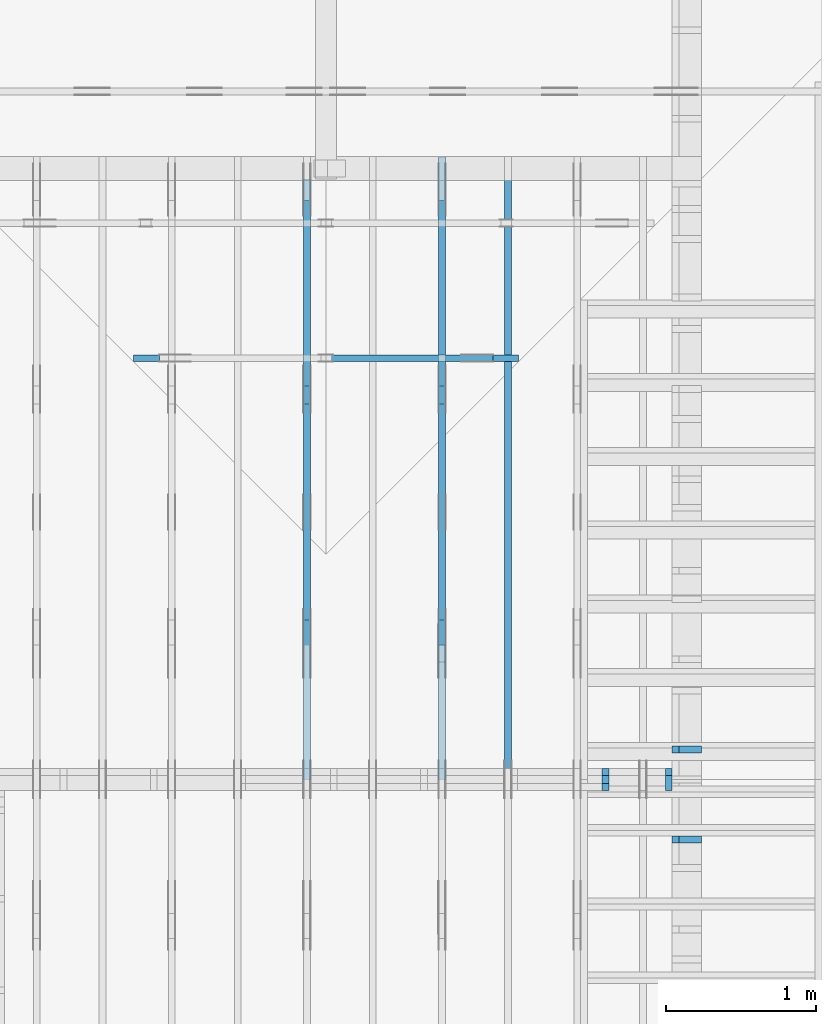
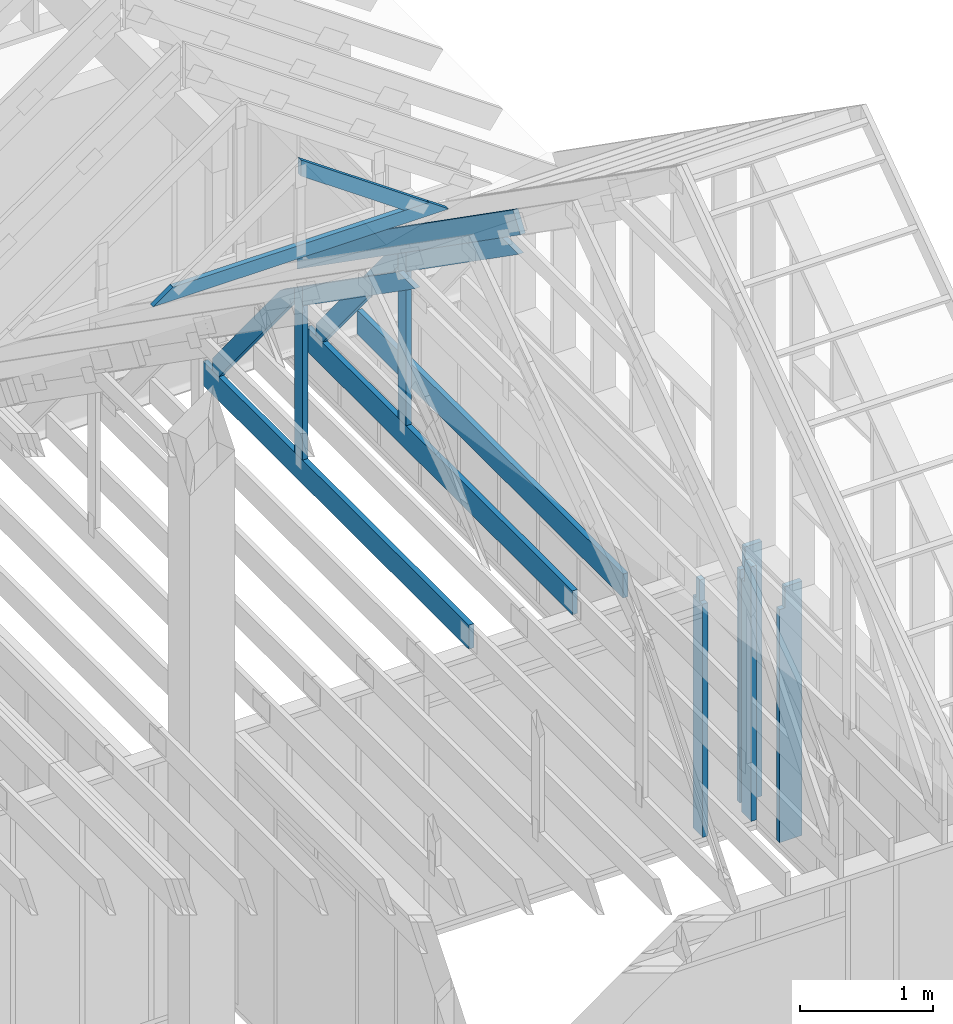
# One storey, part 26 of 70: 16 members, 6 elements without a shape of their own.
"""IFC2X3 building model written with IfcOpenShell, lengths in millimetres."""

from ifc_helpers import new_model, si_unit, frame, origin, origin_with_axes, origin_2d, place, context, project, spatial, faceted_brep, element, aggregate, save


model = new_model("IFC2X3")

# Units and contexts
model_context = context("Model", 3, precision=1e-05, world=origin())
plan_context = context("Plan", 2, precision=1e-05, world=origin_2d())
ifc_project = project(units=[si_unit("LENGTHUNIT", "METRE", prefix="MILLI"), si_unit("AREAUNIT", "SQUARE_METRE"), si_unit("VOLUMEUNIT", "CUBIC_METRE"), si_unit("SOLIDANGLEUNIT", "STERADIAN"), si_unit("PLANEANGLEUNIT", "RADIAN"), si_unit("MASSUNIT", "GRAM"), si_unit("TIMEUNIT", "SECOND"), si_unit("THERMODYNAMICTEMPERATUREUNIT", "DEGREE_CELSIUS"), si_unit("LUMINOUSINTENSITYUNIT", "LUMEN")], contexts=[model_context, plan_context])

# Site, building, storey
site_placement = place(None, origin_with_axes())
site = spatial("IfcSite", under=ifc_project, at=site_placement, CompositionType="ELEMENT")
building_placement = place(site_placement, origin_with_axes())
building = spatial("IfcBuilding", under=site, at=building_placement, Name="Layout 1", CompositionType="ELEMENT")
storey_placement = place(building_placement, origin_with_axes())
storey = spatial("IfcBuildingStorey", under=building, at=storey_placement, Name="Storey 1", CompositionType="ELEMENT", Elevation=0.0)

# Assembly, members
assembly_1_placement = place(storey_placement, frame((12000.0, 0.0, -2470.0), z_axis=(1.0, -6.123031769111886e-17, 6.123031769111886e-17), x_axis=(6.123031769111886e-17, 1.0, 0.0)))
assembly_1 = element("IfcElementAssembly", 1, at=assembly_1_placement, inside=storey, Name="VE5", AssemblyPlace="FACTORY", PredefinedType="NOTDEFINED")
member_1_placement = place(assembly_1_placement, frame((3577.5000000018335, 2425.0, -195.00000000000003), z_axis=(0.0, 0.0, 1.0), x_axis=(-1.836909530733566e-16, -1.0, 0.0)))
member_1 = element("IfcMember", 2, at=member_1_placement, Name="S1", context=model_context, shape_type="Brep", body=[
    faceted_brep([(0.0, 45.0, 45.00000000000003), (195.00000000186265, 45.0, 45.00000000000005), (195.00000000186265, 0.0, 45.00000000000005), (0.0, 0.0, 45.00000000000003), (195.00000000186265, -2.1311460639909362e-46, 2.842170943040401e-14), (195.00000000186265, -3.3742366240998114e-31, 45.00000000000003), (195.00000000186265, 45.0, 45.00000000000003), (195.00000000186265, 45.0, 2.842170943040401e-14), (2.7553642961003504e-15, -3.3742366240998114e-31, 45.00000000000003), (1.193991194976818e-14, -1.4621692037765842e-30, 195.00000000000003), (1.7450640541968876e-14, 45.0, 195.00000000000003), (8.266092888301048e-15, 45.0, 45.00000000000003), (2335.0, -4.2891837542628763e-13, 2.842170943040403e-14), (2335.0, -4.1697846347651946e-13, 195.00000000000003), (2.1932538056648764e-30, 1.193991194976818e-14, 195.00000000000003), (5.061354936149717e-31, 2.7553642961003504e-15, 45.00000000000003), (195.00000000186265, -3.306437155354634e-14, 45.00000000000003), (195.00000000186265, -3.5819735849646686e-14, 2.842170943040401e-14), (-1.6871183120499057e-31, 45.0, 45.00000000000003), (-7.310846018882921e-31, 44.999999999999986, 195.00000000000003), (2335.0, 44.999999999999844, 195.00000000000003), (2335.0, 44.99999999999986, 2.8421709430403998e-14), (195.00000000186265, 44.999999999999986, 2.842170943040401e-14), (195.00000000186265, 44.999999999999986, 45.00000000000003), (2335.0, 45.000000000000455, 0.0), (2335.0, 45.000000000000455, 195.00000000000003), (2335.0, 4.547473508864641e-13, 195.00000000000003), (2335.0, 4.547473508864641e-13, 0.0), (2335.0, 45.000000000000455, 195.00000000000003), (0.0, 45.000000000000455, 195.00000000000003), (0.0, 0.0, 195.00000000000003), (2335.0, 0.0, 195.00000000000003), (195.00000000186265, 45.0, 5.2301533330168465e-14), (2335.0, 45.0, 3.143672930479291e-13), (2335.0, 4.547473508864641e-13, 3.143672930479291e-13), (195.00000000186265, 4.547473508864641e-13, 5.2301533330168465e-14)], [[[0, 1, 2, 3]], [[4, 5, 6, 7]], [[8, 9, 10, 11]], [[12, 13, 14, 15, 16, 17]], [[18, 19, 20, 21, 22, 23]], [[24, 25, 26, 27]], [[28, 29, 30, 31]], [[32, 33, 34, 35]]]),
])
member_2_placement = place(assembly_1_placement, frame((4177.5000000018335, 2425.0, -195.00000000000003), z_axis=(0.0, 0.0, 1.0), x_axis=(-1.836909530733566e-16, -1.0, 0.0)))
member_2 = element("IfcMember", 3, at=member_2_placement, Name="S11", context=model_context, shape_type="Brep", body=[
    faceted_brep([(0.0, 45.0, 45.00000000000003), (195.00000000186265, 45.0, 45.00000000000005), (195.00000000186265, 0.0, 45.00000000000005), (0.0, 0.0, 45.00000000000003), (195.00000000186265, -2.1311460639909362e-46, 2.842170943040401e-14), (195.00000000186265, -3.3742366240998114e-31, 45.00000000000003), (195.00000000186265, 45.0, 45.00000000000003), (195.00000000186265, 45.0, 2.842170943040401e-14), (2.7553642961003504e-15, -3.3742366240998114e-31, 45.00000000000003), (1.193991194976818e-14, -1.4621692037765842e-30, 195.00000000000003), (1.7450640541968876e-14, 45.0, 195.00000000000003), (8.266092888301048e-15, 45.0, 45.00000000000003), (2335.0, -4.2891837542628763e-13, 2.842170943040403e-14), (2335.0, -4.1697846347651946e-13, 195.00000000000003), (2.1932538056648764e-30, 1.193991194976818e-14, 195.00000000000003), (5.061354936149717e-31, 2.7553642961003504e-15, 45.00000000000003), (195.00000000186265, -3.306437155354634e-14, 45.00000000000003), (195.00000000186265, -3.5819735849646686e-14, 2.842170943040401e-14), (-1.6871183120499057e-31, 45.0, 45.00000000000003), (-7.310846018882921e-31, 44.999999999999986, 195.00000000000003), (2335.0, 44.999999999999844, 195.00000000000003), (2335.0, 44.99999999999986, 2.8421709430403998e-14), (195.00000000186265, 44.999999999999986, 2.842170943040401e-14), (195.00000000186265, 44.999999999999986, 45.00000000000003), (2335.0, 45.0, 0.0), (2335.0, 45.0, 195.00000000000003), (2335.0, 0.0, 195.00000000000003), (2335.0, 0.0, 0.0), (2335.0, 45.0, 195.00000000000003), (0.0, 45.0, 195.00000000000003), (0.0, 0.0, 195.00000000000003), (2335.0, 0.0, 195.00000000000003), (195.00000000186265, 45.0, 5.2301533330168465e-14), (2335.0, 45.0, 3.143672930479291e-13), (2335.0, 0.0, 3.143672930479291e-13), (195.00000000186265, 0.0, 5.2301533330168465e-14)], [[[0, 1, 2, 3]], [[4, 5, 6, 7]], [[8, 9, 10, 11]], [[12, 13, 14, 15, 16, 17]], [[18, 19, 20, 21, 22, 23]], [[24, 25, 26, 27]], [[28, 29, 30, 31]], [[32, 33, 34, 35]]]),
])
aggregate(assembly_1, [member_1, member_2])

assembly_2_placement = place(storey_placement, frame((-48.55339059327651, 3927.500000000001, -2470.0), z_axis=(0.0, -1.0, 6.123031769111886e-17), x_axis=(1.0, 0.0, 0.0)))
assembly_2 = element("IfcElementAssembly", 4, at=assembly_2_placement, inside=storey, Name="VE8", AssemblyPlace="FACTORY", PredefinedType="NOTDEFINED")
member_3_placement = place(assembly_2_placement, frame((11808.5533905942, 2425.0, -145.0), z_axis=(0.0, 0.0, 1.0), x_axis=(-1.836909530733566e-16, -1.0, 0.0)))
member_3 = element("IfcMember", 5, at=member_3_placement, Name="S42", context=model_context, shape_type="Brep", body=[
    faceted_brep([(0.0, 45.0, 45.0), (195.00000000186265, 45.0, 45.00000000000002), (195.00000000186265, 1.862645149230957e-09, 45.00000000000002), (0.0, 1.862645149230957e-09, 45.0), (195.00000000186265, 1.7062120605260134e-09, 0.0), (195.00000000186265, 1.7062120605260134e-09, 45.0), (195.00000000186265, 45.0, 45.0), (195.00000000186265, 45.0, 0.0), (2.7553642963284495e-15, 1.862645149230957e-09, 45.0), (8.878396065440336e-15, 1.862645149230957e-09, 145.0), (1.4389124657412933e-14, 45.0, 145.0), (8.266092888301046e-15, 45.0, 45.0), (2335.0, 1.8622162308555307e-09, 2.626280839091018e-29), (2335.0, 1.862225109251596e-09, 145.0), (1.6308810349815745e-30, 1.8626540276270222e-09, 145.0), (5.061354936149714e-31, 1.862647904595253e-09, 45.0), (195.00000000186265, 1.8626120848594034e-09, 45.0), (195.00000000186265, 1.8626093294951073e-09, 2.193253805687835e-30), (-1.6871183120499046e-31, 45.0, 45.0), (-5.436270116605248e-31, 44.99999999999999, 145.0), (2335.0, 44.99999999999985, 145.0), (2335.0, 44.99999999999986, -8.67746995743113e-30), (195.00000000186265, 44.999999999999986, -7.888609052210118e-31), (195.00000000186265, 44.999999999999986, 45.0), (2335.0, 45.0, 2.842170943040401e-14), (2335.0, 45.0, 145.0), (2335.0, 0.0, 145.0), (2335.0, 0.0, 0.0), (2335.0, 45.0, 145.0), (0.0, 45.0, 145.0), (0.0, 1.862645149230957e-09, 145.0), (2335.0, 1.862645149230957e-09, 145.0), (195.00000000186265, 45.0, 2.3879823899764457e-14), (2335.0, 45.0, 2.859455836175251e-13), (2335.0, 0.0, 2.859455836175251e-13), (195.00000000186265, 0.0, 2.3879823899764457e-14)], [[[0, 1, 2, 3]], [[4, 5, 6, 7]], [[8, 9, 10, 11]], [[12, 13, 14, 15, 16, 17]], [[18, 19, 20, 21, 22, 23]], [[24, 25, 26, 27]], [[28, 29, 30, 31]], [[32, 33, 34, 35]]]),
])
member_4_placement = place(assembly_2_placement, frame((11387.500000003667, 2425.0, -145.0), z_axis=(0.0, 0.0, 1.0), x_axis=(-1.836909530733566e-16, -1.0, 0.0)))
member_4 = element("IfcMember", 6, at=member_4_placement, Name="S43", context=model_context, shape_type="Brep", body=[
    faceted_brep([(195.0, -8.551841827674034e-58, 1.14050354233233e-25), (195.0, -3.3742366240998092e-31, 45.0), (195.0, 45.00000000001273, 45.0), (195.0, 45.00000000001273, 1.14050354233233e-25), (195.0, -7.498303609110687e-31, 100.0), (195.0, -1.0872540233210496e-30, 145.0), (195.00000000000003, 45.00000000001273, 145.0), (195.0, 45.00000000001273, 100.0), (195.0, 45.00000000001273, 100.0), (0.0, 45.00000000001273, 100.0), (0.0, 0.0, 100.0), (195.0, 0.0, 100.0), (2335.0, 45.0, 145.0), (195.0, 45.0, 145.0), (195.0, 0.0, 145.0), (2335.0, 0.0, 145.0), (2335.0, -4.2891837542628763e-13, 2.626280839091018e-29), (2335.0, -4.200399793610754e-13, 145.0), (195.0, -2.69413397840923e-14, 145.0), (195.0, -2.969670408019265e-14, 100.0), (1.124745541366603e-30, 6.123031769111886e-15, 100.0), (5.061354936149714e-31, 2.755364296100349e-15, 45.0), (195.0, -3.3064371553204186e-14, 45.0), (195.0, -3.5819735849304535e-14, 2.193253805685826e-30), (0.0, 45.00000000001455, 45.0), (195.00000000186265, 45.00000000001455, 45.00000000000002), (195.00000000186265, 0.0, 45.00000000000002), (0.0, 0.0, 45.0), (2.755364296100349e-15, -3.3742366240998092e-31, 45.0), (6.123031769111886e-15, -7.498303609110687e-31, 100.0), (1.1633760361314367e-14, 45.00000000001455, 100.0), (8.26609288830283e-15, 45.00000000001455, 45.0), (-1.6871183120499046e-31, 45.00000000001273, 45.0), (-3.7491518045553436e-31, 45.000000000012726, 100.0), (195.0, 45.00000000001271, 100.0), (195.0, 45.00000000001271, 145.0), (2335.0, 45.000000000012584, 145.0), (2335.0, 45.00000000001259, -8.67746995743113e-30), (195.0, 45.00000000001272, -7.888609052210118e-31), (195.0, 45.00000000001272, 45.0), (2335.0, 45.0, 2.842170943040401e-14), (2335.0, 45.0, 145.0), (2335.0, 0.0, 145.0), (2335.0, 0.0, 0.0), (195.00000000186265, 45.00000000001273, 2.3879823899764457e-14), (2335.0, 45.00000000001273, 2.859455836175251e-13), (2335.0, 0.0, 2.859455836175251e-13), (195.00000000186265, 0.0, 2.3879823899764457e-14)], [[[0, 1, 2, 3]], [[4, 5, 6, 7]], [[8, 9, 10, 11]], [[12, 13, 14, 15]], [[16, 17, 18, 19, 20, 21, 22, 23]], [[24, 25, 26, 27]], [[28, 29, 30, 31]], [[32, 33, 34, 35, 36, 37, 38, 39]], [[40, 41, 42, 43]], [[44, 45, 46, 47]]]),
])
aggregate(assembly_2, [member_3, member_4])

# Assembly, member
assembly_3_placement = place(storey_placement, frame((10688.750000000146, 8000.0, 1.3776821480501744e-15), z_axis=(-1.0, 1.836909530733566e-16, 6.123031769111886e-17), x_axis=(-1.836909530733566e-16, -1.0, 0.0)))
assembly_3 = element("IfcElementAssembly", 7, at=assembly_3_placement, inside=storey, Name="MB1", AssemblyPlace="FACTORY", PredefinedType="TRUSS")
member_5_placement = place(assembly_3_placement, frame((4000.0000000000005, 219.99999999999997, -45.0), z_axis=(0.0, 0.0, 1.0), x_axis=(-1.0, 1.2246063538223773e-16, 0.0)))
member_5 = element("IfcMember", 8, at=member_5_placement, Name="B3", context=model_context, shape_type="Brep", body=[
    faceted_brep([(4000.0000000000005, 220.00000000000045, 45.0), (0.0, 220.00000000000045, 45.0), (0.0, 0.0, 45.0), (4000.0000000000005, 0.0, 45.0), (0.0, 220.00000000000045, 0.0), (4000.0000000000005, 220.00000000000045, 4.89842541528951e-13), (4000.0000000000005, 0.0, 4.89842541528951e-13), (0.0, 0.0, 0.0), (0.0, 0.0, 0.0), (2.755364296100349e-15, -3.3742366240998092e-31, 45.0), (2.969670408019265e-14, 220.0, 45.0), (2.69413397840923e-14, 220.0, -1.6496267940043512e-30), (4000.0000000000005, -7.347638122934265e-13, 7.283414641863702e-29), (4000.0000000000005, -7.320084479973261e-13, 45.0), (5.061354936149714e-31, 2.755364296100349e-15, 45.0), (0.0, 0.0, 0.0), (4000.0000000000005, 220.00000000000045, 0.0), (4000.0000000000005, 220.00000000000045, 45.0), (4000.0000000000005, 4.547473508864641e-13, 45.0), (4000.0000000000005, 4.547473508864641e-13, 0.0), (0.0, 220.0, 0.0), (0.0, 220.0, 45.0), (4000.0000000000005, 220.00000000000065, 45.0), (4000.0000000000005, 220.00000000000065, 1.1044052673094165e-29)], [[[0, 1, 2, 3]], [[4, 5, 6, 7]], [[8, 9, 10, 11]], [[12, 13, 14, 15]], [[16, 17, 18, 19]], [[20, 21, 22, 23]]]),
])
aggregate(assembly_3, [member_5])

# Assembly, members
assembly_4_placement = place(storey_placement, frame((10250.0, 8000.0, -9.081170196248781e-13), z_axis=(-1.0, 1.836909530733566e-16, 6.123031769111886e-17), x_axis=(-1.836909530733566e-16, -1.0, 0.0)))
assembly_4 = element("IfcElementAssembly", 9, at=assembly_4_placement, inside=storey, Name="T3", AssemblyPlace="FACTORY", PredefinedType="TRUSS")
member_6_placement = place(assembly_4_placement, frame((-145.0000000000008, 660.4188621509819, -45.0), z_axis=(0.0, 0.0, 1.0), x_axis=(0.8191520442889915, 0.5735764363510465, 0.0)))
member_6 = element("IfcMember", 10, at=member_6_placement, Name="T10", context=model_context, shape_type="Brep", body=[
    faceted_brep([(4105.08693981286, 195.00000000242483, 45.0), (136.5404699510177, 195.00000000242483, 45.0), (0.0, 0.0, 45.0), (4105.08693981249, 0.0, 45.0), (136.5404699510177, 195.00000000242483, 1.6720832705590965e-14), (4105.08693981286, 195.00000000242483, 5.027115549488087e-13), (4105.08693981249, 0.0, 5.027115549487634e-13), (0.0, 0.0, 0.0), (-1.1640850691051581e-14, 8.151011405048023e-15, 8.701351488741532e-31), (-9.383788395140082e-15, 6.570599371241877e-15, 45.0), (136.54046995101766, 195.00000000017752, 45.0), (136.54046995101766, 195.00000000017752, 4.814439674979212e-30), (4105.08693981249, 2.4530373342863473e-09, 2.683789629641233e-29), (4105.08693981249, 2.4530400896506434e-09, 45.0), (-1.646496550984743e-27, 2.755364296100349e-15, 45.0), (0.0, 0.0, 0.0), (4105.08693981249, 195.00000000242483, -2.2668706972430995e-26), (4105.08693981249, 195.00000000242483, 45.0), (4105.08693981249, 2.4534756448701955e-09, 45.0), (4105.08693981249, 2.4534756448701955e-09, 0.0), (136.5404699510177, 195.00000000017747, 0.0), (136.5404699510177, 195.00000000017747, 45.0), (4105.08693981286, 195.00000000242514, 45.0), (4105.08693981286, 195.00000000242514, 1.8932661725304283e-29)], [[[0, 1, 2, 3]], [[4, 5, 6, 7]], [[8, 9, 10, 11]], [[12, 13, 14, 15]], [[16, 17, 18, 19]], [[20, 21, 22, 23]]]),
])
member_7_placement = place(assembly_4_placement, frame((3999.9999999999995, 220.0, -45.0), z_axis=(0.0, 0.0, 1.0), x_axis=(-1.0, 1.2246063538223773e-16, 0.0)))
member_7 = element("IfcMember", 11, at=member_7_placement, Name="B3", context=model_context, shape_type="Brep", body=[
    faceted_brep([(3999.9999999999995, 220.00000000000048, 45.0), (0.0, 220.00000000000048, 45.0), (0.0, 0.0, 45.0), (4000.0, 0.0, 45.0), (0.0, 220.00000000000048, 0.0), (3999.9999999999995, 220.00000000000048, 4.898425415289508e-13), (4000.0, 0.0, 4.898425415289509e-13), (0.0, 0.0, 0.0), (0.0, 0.0, 0.0), (2.755364296100349e-15, -3.3742366240998092e-31, 45.0), (2.969670408019265e-14, 220.0, 45.0), (2.69413397840923e-14, 220.0, -1.6496267940043512e-30), (4000.0, -7.347638122934264e-13, 7.457441671638533e-29), (4000.0, -7.32008447997326e-13, 45.0), (5.061354936149714e-31, 2.755364296100349e-15, 45.0), (0.0, 0.0, 0.0), (4000.0, 220.00000000000048, 5.048709793414476e-29), (4000.0, 220.00000000000048, 45.0), (4000.0, 4.831690603168681e-13, 45.0), (4000.0, 4.831690603168681e-13, 0.0), (0.0, 220.0, 0.0), (0.0, 220.0, 45.0), (3999.9999999999995, 220.00000000000065, 45.0), (3999.9999999999995, 220.00000000000065, 9.466330862652142e-30)], [[[0, 1, 2, 3]], [[4, 5, 6, 7]], [[8, 9, 10, 11]], [[12, 13, 14, 15]], [[16, 17, 18, 19]], [[20, 21, 22, 23]]]),
])
member_8_placement = place(assembly_4_placement, frame((1500.000000004151, 1635.2479181252359, -45.0), z_axis=(0.0, 0.0, 1.0), x_axis=(0.8191520442886487, 0.5735764363515361, 0.0)))
member_8 = element("IfcMember", 12, at=member_8_placement, Name="SC5", context=model_context, shape_type="Brep", body=[
    faceted_brep([(1858.470759764839, 145.00000000273417, 45.0), (101.53009304261923, 145.00000000273417, 45.0), (0.0, 4.395587893668562e-09, 45.0), (2065.5522207463405, 4.395587893668562e-09, 45.0), (101.53009304261923, 145.00000000273417, 1.2433439704416865e-14), (1858.470759764839, 145.00000000273417, 2.2758951008011226e-13), (2065.5522207463405, 4.395587893668562e-09, 2.52948837367789e-13), (0.0, 4.395587893668562e-09, 0.0), (8.6935104615022825e-16, 4.395587284942406e-09, -6.498261357111438e-32), (3.1264133420566933e-15, 4.395585704530372e-09, 45.0), (101.5300930426192, 145.00000000701368, 45.0), (101.5300930426192, 145.00000000701368, 1.9667596592082453e-30), (2065.5522207463405, -4.425913119322423e-13, 2.71000066369662e-29), (2065.5522207463405, -4.3983594763614193e-13, 45.0), (5.864129370369717e-27, 4.395590649032858e-09, 45.0), (0.0, 4.395587893668562e-09, 0.0), (1858.470759764839, 145.00000000273428, 0.0), (1858.470759764839, 145.00000000273428, 45.0), (2065.552220746341, -1.1368683772161603e-13, 45.0), (2065.552220746341, -1.1368683772161603e-13, 0.0), (101.53009304261923, 145.00000000701368, 1.5777218104420236e-30), (101.53009304261923, 145.00000000701368, 45.0), (1858.470759764839, 145.00000000273437, 45.0), (1858.470759764839, 145.00000000273437, 1.262177448353619e-29)], [[[0, 1, 2, 3]], [[4, 5, 6, 7]], [[8, 9, 10, 11]], [[12, 13, 14, 15]], [[16, 17, 18, 19]], [[20, 21, 22, 23]]]),
])
member_9_placement = place(assembly_4_placement, frame((1380.0000000018192, 1812.2602625085638, -45.0), z_axis=(0.0, 0.0, 1.0), x_axis=(-1.836909530733566e-16, -1.0, 0.0)))
member_9 = element("IfcMember", 13, at=member_9_placement, Name="R1", context=model_context, shape_type="Brep", body=[
    faceted_brep([(1592.2602625085638, 120.00000000001455, 45.0), (0.0, 120.00000000001455, 45.0), (84.02490458526881, 1.432454155292362e-11, 45.0), (1592.2602625085638, 1.432454155292362e-11, 45.0), (0.0, 120.00000000001455, 0.0), (1592.2602625085638, 120.00000000001455, 1.9498920344068735e-13), (1592.2602625085638, 1.432454155292362e-11, 1.9498920344068735e-13), (84.02490458526881, 1.432454155292362e-11, 1.0289743203443919e-14), (84.0249045852688, 1.4303225270850817e-11, 1.5777218104420236e-30), (84.02490458526881, 1.4303225270850817e-11, 45.0), (2.1316282072803006e-14, 120.00000000001435, 45.0), (2.1316282072803006e-14, 120.00000000001435, -2.3665827156630354e-30), (1592.2602625085638, -7.262347142616226e-13, 4.446758227255812e-29), (1592.2602625085638, -7.234793499655223e-13, 45.0), (84.02490458526881, 1.4288972904488156e-11, 45.0), (84.02490458526881, 1.4286217540192056e-11, 2.3465914747521543e-30), (1592.2602625085638, 120.00000000001455, 0.0), (1592.2602625085638, 120.00000000001455, 45.0), (1592.2602625085638, 0.0, 45.0), (1592.2602625085638, 0.0, 0.0), (0.0, 120.00000000001432, 0.0), (0.0, 120.00000000001432, 45.0), (1592.2602625085638, 120.00000000001458, 45.0), (1592.2602625085638, 120.00000000001458, 1.5777218104420236e-30)], [[[0, 1, 2, 3]], [[4, 5, 6, 7]], [[8, 9, 10, 11]], [[12, 13, 14, 15]], [[16, 17, 18, 19]], [[20, 21, 22, 23]]]),
])
member_10_placement = place(assembly_4_placement, frame((1323.9061318638364, 1774.1671329521819, -45.0), z_axis=(0.0, 0.0, 1.0), x_axis=(-0.6335417245359891, -0.7737085260432154, 0.0)))
member_10 = element("IfcMember", 14, at=member_10_placement, Name="W6", context=model_context, shape_type="Brep", body=[
    faceted_brep([(1889.9928508901896, 145.00000000000045, 45.0), (88.54013234780132, 145.00000000000045, 45.0), (0.0, 72.4999999998246, 45.0), (258.1329393158155, 1.0373923942097463e-12, 45.0), (1860.818453163112, 1.0373923942097463e-12, 45.0), (1949.358585509489, 72.4999999998246, 45.0), (88.54013234780132, 145.00000000000045, 1.0842680864139169e-14), (1889.9928508901896, 145.00000000000045, 2.314497253878995e-13), (1949.358585509489, 72.4999999998246, 2.387196909693122e-13), (1860.818453163112, 1.0373923942097463e-12, 2.278770101053475e-13), (258.1329393158155, 1.0373923942097463e-12, 3.161112376169938e-14), (0.0, 72.4999999998246, 0.0), (1.4210854715202004e-14, 72.49999999982458, -1.1832913578315177e-30), (1.4210854715202004e-14, 72.49999999982458, 45.0), (88.54013234780135, 145.00000000000057, 45.0), (88.54013234780135, 145.00000000000057, -7.888609052210118e-31), (258.13293931581546, 9.094947017729282e-13, 9.44327198188855e-30), (258.13293931581546, 9.094947017729282e-13, 45.0), (0.0, 72.49999999982461, 45.0), (0.0, 72.49999999982461, -8.492704648594505e-31), (1860.818453163112, -7.900766401995888e-13, 4.837664367975264e-29), (1860.818453163112, -7.873212759034885e-13, 45.0), (258.1329393158155, 9.305482405771586e-13, 45.0), (258.1329393158155, 9.277928762810583e-13, 6.710813301567046e-30), (1949.3585855094898, 72.4999999985605, 7.573064690121713e-29), (1949.3585855094898, 72.4999999985605, 45.0), (1860.8184531631127, -7.958078640513122e-13, 45.0), (1860.8184531631127, -7.958078640513122e-13, 6.310887241768094e-29), (1889.9928508901896, 145.00000000000057, 1.262177448353619e-29), (1889.9928508901896, 145.00000000000057, 45.0), (1949.358585509489, 72.49999999856152, 45.0), (1949.358585509489, 72.49999999856152, 1.262177448353619e-29), (88.54013234780132, 145.00000000000057, 0.0), (88.54013234780132, 145.00000000000057, 45.0), (1889.9928508901896, 145.00000000000045, 45.0), (1889.9928508901896, 145.00000000000045, 0.0)], [[[0, 1, 2, 3, 4, 5]], [[6, 7, 8, 9, 10, 11]], [[12, 13, 14, 15]], [[16, 17, 18, 19]], [[20, 21, 22, 23]], [[24, 25, 26, 27]], [[28, 29, 30, 31]], [[32, 33, 34, 35]]]),
])
aggregate(assembly_4, [member_6, member_7, member_8, member_9, member_10])

assembly_5_placement = place(storey_placement, frame((9350.0, 8000.0, -9.081170196248781e-13), z_axis=(-1.0, 1.836909530733566e-16, 6.123031769111886e-17), x_axis=(-1.836909530733566e-16, -1.0, 0.0)))
assembly_5 = element("IfcElementAssembly", 15, at=assembly_5_placement, inside=storey, Name="T3", AssemblyPlace="FACTORY", PredefinedType="TRUSS")
member_11_placement = place(assembly_5_placement, frame((3999.9999999999995, 220.0, -45.0), z_axis=(0.0, 0.0, 1.0), x_axis=(-1.0, 1.2246063538223773e-16, 0.0)))
member_11 = element("IfcMember", 16, at=member_11_placement, Name="B3", context=model_context, shape_type="Brep", body=[
    faceted_brep([(3999.9999999999995, 220.00000000000048, 45.0), (0.0, 220.00000000000048, 45.0), (0.0, 0.0, 45.0), (4000.0, 0.0, 45.0), (0.0, 220.00000000000048, 0.0), (3999.9999999999995, 220.00000000000048, 4.898425415289508e-13), (4000.0, 0.0, 4.898425415289509e-13), (0.0, 0.0, 0.0), (0.0, 0.0, 0.0), (2.755364296100349e-15, -3.3742366240998092e-31, 45.0), (2.969670408019265e-14, 220.0, 45.0), (2.69413397840923e-14, 220.0, -1.6496267940043512e-30), (4000.0, -7.347638122934264e-13, 7.457441671638533e-29), (4000.0, -7.32008447997326e-13, 45.0), (5.061354936149714e-31, 2.755364296100349e-15, 45.0), (0.0, 0.0, 0.0), (4000.0, 220.00000000000048, 5.048709793414476e-29), (4000.0, 220.00000000000048, 45.0), (4000.0, 4.831690603168681e-13, 45.0), (4000.0, 4.831690603168681e-13, 0.0), (0.0, 220.0, 0.0), (0.0, 220.0, 45.0), (3999.9999999999995, 220.00000000000065, 45.0), (3999.9999999999995, 220.00000000000065, 9.466330862652142e-30)], [[[0, 1, 2, 3]], [[4, 5, 6, 7]], [[8, 9, 10, 11]], [[12, 13, 14, 15]], [[16, 17, 18, 19]], [[20, 21, 22, 23]]]),
])
member_12_placement = place(assembly_5_placement, frame((1500.000000004151, 1635.2479181252359, -45.0), z_axis=(0.0, 0.0, 1.0), x_axis=(0.8191520442886487, 0.5735764363515361, 0.0)))
member_12 = element("IfcMember", 17, at=member_12_placement, Name="SC5", context=model_context, shape_type="Brep", body=[
    faceted_brep([(1858.470759764839, 145.00000000273417, 45.0), (101.53009304261923, 145.00000000273417, 45.0), (0.0, 4.395587893668562e-09, 45.0), (2065.5522207463405, 4.395587893668562e-09, 45.0), (101.53009304261923, 145.00000000273417, 1.2433439704416865e-14), (1858.470759764839, 145.00000000273417, 2.2758951008011226e-13), (2065.5522207463405, 4.395587893668562e-09, 2.52948837367789e-13), (0.0, 4.395587893668562e-09, 0.0), (8.6935104615022825e-16, 4.395587284942406e-09, -6.498261357111438e-32), (3.1264133420566933e-15, 4.395585704530372e-09, 45.0), (101.5300930426192, 145.00000000701368, 45.0), (101.5300930426192, 145.00000000701368, 1.9667596592082453e-30), (2065.5522207463405, -4.425913119322423e-13, 2.71000066369662e-29), (2065.5522207463405, -4.3983594763614193e-13, 45.0), (5.864129370369717e-27, 4.395590649032858e-09, 45.0), (0.0, 4.395587893668562e-09, 0.0), (1858.470759764839, 145.00000000273428, 0.0), (1858.470759764839, 145.00000000273428, 45.0), (2065.552220746341, -1.1368683772161603e-13, 45.0), (2065.552220746341, -1.1368683772161603e-13, 0.0), (101.53009304261923, 145.00000000701368, 1.5777218104420236e-30), (101.53009304261923, 145.00000000701368, 45.0), (1858.470759764839, 145.00000000273437, 45.0), (1858.470759764839, 145.00000000273437, 1.262177448353619e-29)], [[[0, 1, 2, 3]], [[4, 5, 6, 7]], [[8, 9, 10, 11]], [[12, 13, 14, 15]], [[16, 17, 18, 19]], [[20, 21, 22, 23]]]),
])
member_13_placement = place(assembly_5_placement, frame((1380.0000000018192, 1812.2602625085638, -45.0), z_axis=(0.0, 0.0, 1.0), x_axis=(-1.836909530733566e-16, -1.0, 0.0)))
member_13 = element("IfcMember", 18, at=member_13_placement, Name="R1", context=model_context, shape_type="Brep", body=[
    faceted_brep([(1592.2602625085638, 120.00000000001455, 45.0), (0.0, 120.00000000001455, 45.0), (84.02490458526881, 1.432454155292362e-11, 45.0), (1592.2602625085638, 1.432454155292362e-11, 45.0), (0.0, 120.00000000001455, 0.0), (1592.2602625085638, 120.00000000001455, 1.9498920344068735e-13), (1592.2602625085638, 1.432454155292362e-11, 1.9498920344068735e-13), (84.02490458526881, 1.432454155292362e-11, 1.0289743203443919e-14), (84.0249045852688, 1.4303225270850817e-11, 1.5777218104420236e-30), (84.02490458526881, 1.4303225270850817e-11, 45.0), (2.1316282072803006e-14, 120.00000000001435, 45.0), (2.1316282072803006e-14, 120.00000000001435, -2.3665827156630354e-30), (1592.2602625085638, -7.262347142616226e-13, 4.446758227255812e-29), (1592.2602625085638, -7.234793499655223e-13, 45.0), (84.02490458526881, 1.4288972904488156e-11, 45.0), (84.02490458526881, 1.4286217540192056e-11, 2.3465914747521543e-30), (1592.2602625085638, 120.00000000001455, 0.0), (1592.2602625085638, 120.00000000001455, 45.0), (1592.2602625085638, 0.0, 45.0), (1592.2602625085638, 0.0, 0.0), (0.0, 120.00000000001432, 0.0), (0.0, 120.00000000001432, 45.0), (1592.2602625085638, 120.00000000001458, 45.0), (1592.2602625085638, 120.00000000001458, 1.5777218104420236e-30)], [[[0, 1, 2, 3]], [[4, 5, 6, 7]], [[8, 9, 10, 11]], [[12, 13, 14, 15]], [[16, 17, 18, 19]], [[20, 21, 22, 23]]]),
])
member_14_placement = place(assembly_5_placement, frame((1323.9061318638364, 1774.1671329521819, -45.0), z_axis=(0.0, 0.0, 1.0), x_axis=(-0.6335417245359891, -0.7737085260432154, 0.0)))
member_14 = element("IfcMember", 19, at=member_14_placement, Name="W6", context=model_context, shape_type="Brep", body=[
    faceted_brep([(1889.9928508901896, 145.00000000000045, 45.0), (88.54013234780132, 145.00000000000045, 45.0), (0.0, 72.4999999998246, 45.0), (258.1329393158155, 1.0373923942097463e-12, 45.0), (1860.818453163112, 1.0373923942097463e-12, 45.0), (1949.358585509489, 72.4999999998246, 45.0), (88.54013234780132, 145.00000000000045, 1.0842680864139169e-14), (1889.9928508901896, 145.00000000000045, 2.314497253878995e-13), (1949.358585509489, 72.4999999998246, 2.387196909693122e-13), (1860.818453163112, 1.0373923942097463e-12, 2.278770101053475e-13), (258.1329393158155, 1.0373923942097463e-12, 3.161112376169938e-14), (0.0, 72.4999999998246, 0.0), (1.4210854715202004e-14, 72.49999999982458, -1.1832913578315177e-30), (1.4210854715202004e-14, 72.49999999982458, 45.0), (88.54013234780135, 145.00000000000057, 45.0), (88.54013234780135, 145.00000000000057, -7.888609052210118e-31), (258.13293931581546, 9.094947017729282e-13, 9.44327198188855e-30), (258.13293931581546, 9.094947017729282e-13, 45.0), (0.0, 72.49999999982461, 45.0), (0.0, 72.49999999982461, -8.492704648594505e-31), (1860.818453163112, -7.900766401995888e-13, 4.837664367975264e-29), (1860.818453163112, -7.873212759034885e-13, 45.0), (258.1329393158155, 9.305482405771586e-13, 45.0), (258.1329393158155, 9.277928762810583e-13, 6.710813301567046e-30), (1949.3585855094898, 72.4999999985605, 7.573064690121713e-29), (1949.3585855094898, 72.4999999985605, 45.0), (1860.8184531631127, -7.958078640513122e-13, 45.0), (1860.8184531631127, -7.958078640513122e-13, 6.310887241768094e-29), (1889.9928508901896, 145.00000000000057, 1.262177448353619e-29), (1889.9928508901896, 145.00000000000057, 45.0), (1949.358585509489, 72.49999999856152, 45.0), (1949.358585509489, 72.49999999856152, 1.262177448353619e-29), (88.54013234780132, 145.00000000000057, 0.0), (88.54013234780132, 145.00000000000057, 45.0), (1889.9928508901896, 145.00000000000045, 45.0), (1889.9928508901896, 145.00000000000045, 0.0)], [[[0, 1, 2, 3, 4, 5]], [[6, 7, 8, 9, 10, 11]], [[12, 13, 14, 15]], [[16, 17, 18, 19]], [[20, 21, 22, 23]], [[24, 25, 26, 27]], [[28, 29, 30, 31]], [[32, 33, 34, 35]]]),
])
aggregate(assembly_5, [member_11, member_12, member_13, member_14])

assembly_6_placement = place(storey_placement, frame((8194.999999999996, 6782.5, 1836.748008160603), z_axis=(0.0, -1.0, 6.123031769111886e-17), x_axis=(1.0, 0.0, 0.0)))
assembly_6 = element("IfcElementAssembly", 20, at=assembly_6_placement, inside=storey, Name="SB2", AssemblyPlace="FACTORY", PredefinedType="TRUSS")
member_15_placement = place(assembly_6_placement, frame((1236.1708276376787, 815.4725920478948, -45.0), z_axis=(0.0, 0.0, 1.0), x_axis=(0.819152044288992, -0.5735764363510457, 0.0)))
member_15 = element("IfcMember", 21, at=member_15_placement, Name="T21", context=model_context, shape_type="Brep", body=[
    faceted_brep([(1356.4297946101547, 120.00000000002183, 45.0), (0.0, 120.00000000002183, 45.0), (84.02490458540603, 0.0, 45.0), (1185.0520338020606, 0.0, 45.0), (0.0, 120.00000000002183, 0.0), (1356.4297946101547, 120.00000000002183, 1.6610925449935774e-13), (1185.0520338020606, 0.0, 1.4512222502041339e-13), (84.02490458540603, 0.0, 1.0289743203460723e-14), (84.02490458540606, 7.105427357601002e-15, -1.5777218104420236e-30), (84.02490458540606, 7.105427357601002e-15, 45.0), (-1.4210854715202004e-14, 120.00000000034404, 45.0), (-1.4210854715202004e-14, 120.00000000034404, 0.0), (1185.0520338020606, 6.951608451730482e-10, -6.055764416780359e-29), (1185.0520338020606, 6.951636005373443e-10, 45.0), (84.02490458540603, 7.288039541935954e-14, 45.0), (84.02490458540603, 7.012503112325919e-14, -4.293777933776544e-30), (1356.4297946101547, 120.00000000002149, 1.8932661725304283e-29), (1356.4297946101547, 120.00000000002149, 45.0), (1185.0520338020606, 6.938307706150226e-10, 45.0), (1185.0520338020606, 6.938307706150226e-10, 1.8932661725304283e-29), (0.0, 120.00000000034402, 0.0), (0.0, 120.00000000034402, 45.0), (1356.4297946101547, 120.00000000002196, 45.0), (1356.4297946101547, 120.00000000002197, 7.888609052210118e-30)], [[[0, 1, 2, 3]], [[4, 5, 6, 7]], [[8, 9, 10, 11]], [[12, 13, 14, 15]], [[16, 17, 18, 19]], [[20, 21, 22, 23]]]),
])
member_16_placement = place(assembly_6_placement, frame((2587.5, 135.75466960948037, -45.0), z_axis=(0.0, 0.0, 1.0), x_axis=(-1.0, -3.216285744678249e-16, 0.0)))
member_16 = element("IfcMember", 22, at=member_16_placement, Name="B5", context=model_context, shape_type="Brep", body=[
    faceted_brep([(2565.0, 119.99999999999994, 45.0), (0.0, 119.99999999999994, 45.0), (171.3777608089149, 7.105427357601002e-13, 45.0), (2393.622239191085, 7.105427357601002e-13, 45.0), (0.0, 119.99999999999994, 0.0), (2565.0, 119.99999999999994, 3.1411152975543977e-13), (2393.622239191085, 7.105427357601002e-13, 2.931245002763949e-13), (171.3777608089149, 7.105427357601002e-13, 2.0987029479044878e-14), (171.37776080891496, 7.958078640513122e-13, -7.099748146989106e-30), (171.37776080891496, 7.958078640513122e-13, 45.0), (-2.842170943040401e-14, 119.99999999906939, 45.0), (-2.842170943040401e-14, 119.99999999906939, 3.1554436208840472e-30), (2393.622239191085, 3.256524868997643e-13, -1.9939805229775493e-29), (2393.622239191085, 3.2840785119586465e-13, 45.0), (171.3777608089149, 7.366140573918897e-13, 45.0), (171.3777608089149, 7.338586930957893e-13, -1.4276434749368206e-30), (2565.0000000000005, 119.99999999999909, 5.048709793414476e-29), (2565.0000000000005, 119.99999999999909, 45.0), (2393.6222391910856, -6.821210263296962e-13, 45.0), (2393.6222391910856, -6.821210263296962e-13, 5.048709793414476e-29), (0.0, 119.99999999906944, 0.0), (0.0, 119.99999999906944, 45.0), (2565.0, 119.99999999999991, 45.0), (2565.0, 119.99999999999993, -1.5777218104420236e-30)], [[[0, 1, 2, 3]], [[4, 5, 6, 7]], [[8, 9, 10, 11]], [[12, 13, 14, 15]], [[16, 17, 18, 19]], [[20, 21, 22, 23]]]),
])
aggregate(assembly_6, [member_15, member_16])

save(model, "model.ifc")
